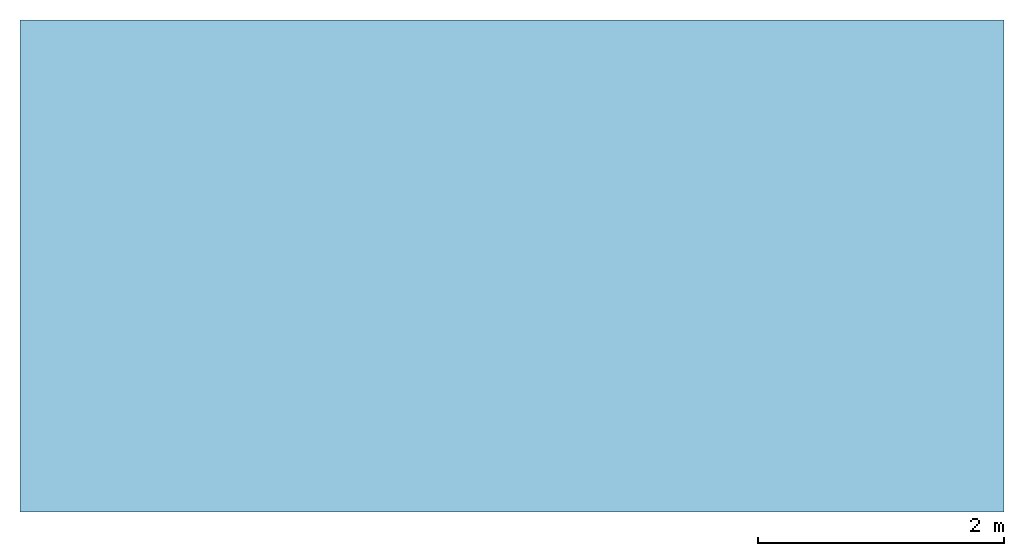
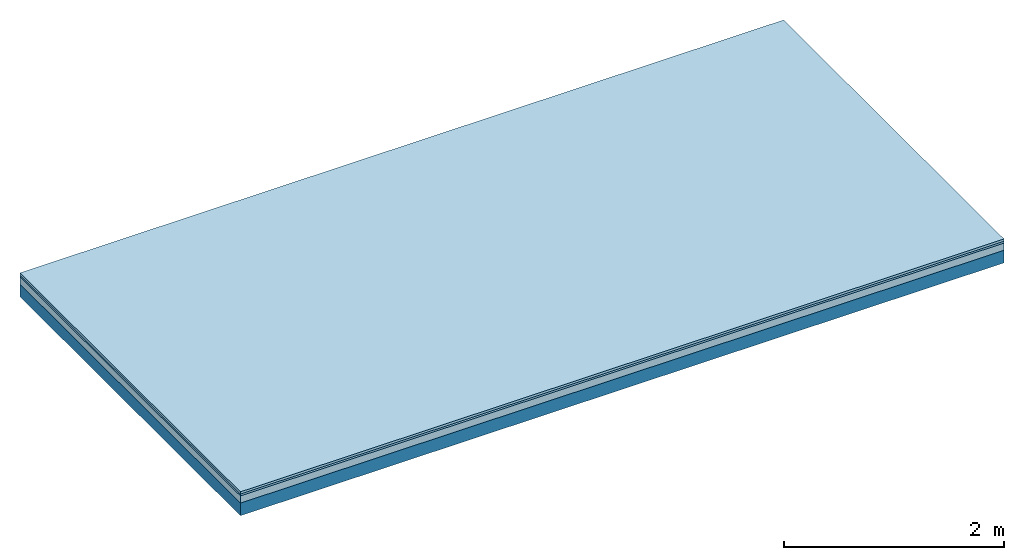
# One storey: 3 plates, 1 member, 1 element without a shape of its own.
"""IFC4 building model written with IfcOpenShell, lengths in metres."""

from ifc_helpers import new_model, si_unit, derived_unit, direction, frame, frame_2d, origin, origin_with_axes, place, context, project, spatial, rectangle, extrude, material, layer, layer_set, type_object, element, aggregate, save


model = new_model("IFC4")

# Units and contexts
plan_context = context("Plan", 3, precision=1e-05, world=origin(), true_north=direction((0.0, 1.0)))
model_context = context("Model", 3, precision=1e-05, world=origin(), true_north=direction((0.0, 1.0)))
ifc_project = project(units=[si_unit("LENGTHUNIT", "METRE"), derived_unit("SOUNDPRESSUREUNIT", [(si_unit("PRESSUREUNIT", "PASCAL", prefix="MICRO"), 0)]), si_unit("ENERGYUNIT", "JOULE", prefix="MEGA"), si_unit("MASSUNIT", "GRAM", prefix="KILO"), derived_unit("THERMALTRANSMITTANCEUNIT", [(si_unit("POWERUNIT", "WATT"), 1), (si_unit("AREAUNIT", "SQUARE_METRE"), -1), (si_unit("THERMODYNAMICTEMPERATUREUNIT", "KELVIN"), -1)]), derived_unit("AREADENSITYUNIT", [(si_unit("MASSUNIT", "GRAM", prefix="KILO"), 1), (si_unit("AREAUNIT", "SQUARE_METRE"), -1)]), derived_unit("USERDEFINED", [(si_unit("ENERGYUNIT", "JOULE", prefix="MEGA"), 1), (si_unit("AREAUNIT", "SQUARE_METRE"), -1)])], contexts=[plan_context, model_context])

# Site, building, storey
site = spatial("IfcSite", under=ifc_project)
building_placement = place(None, origin())
building = spatial("IfcBuilding", under=site, at=building_placement)
storey_placement = place(building_placement, origin())
storey = spatial("IfcBuildingStorey", under=building, at=storey_placement)

# Slab, member, plates
ifc_material_1 = material(Name="Phone TRI ST Star", Category="03.013")
ifc_layer_1 = layer(ifc_material_1, 0.025, Name="On-material")
ifc_material_2 = material(Name="EP3")
ifc_layer_2 = layer(ifc_material_2, 0.02, Name="Impact sound insulation")
ifc_material_3 = material(Category="03.011")
ifc_layer_3 = layer(ifc_material_3, 0.08, Name="on Supporting structure")
ifc_material_4 = material(Name="no composite action")
ifc_layer_4 = layer(ifc_material_4, 0.0, Name="Bond")
ifc_layer_5 = layer(None, 0.14, Name="Supporting structure")
ifc_layer_set = layer_set([ifc_layer_1, ifc_layer_2, ifc_layer_3, ifc_layer_4, ifc_layer_5])
slab_type = type_object("IfcSlabType", Name="A2433", PredefinedType="NOTDEFINED", material=ifc_layer_set)
slab_placement = place(None, frame((0.0, 0.0, 0.0), z_axis=(0.0, 0.0, -1.0), x_axis=(1.0, 0.0, 0.0)))
slab = element("IfcSlab", 1, at=slab_placement, inside=storey, type_object=slab_type, material=ifc_layer_set, Name="Slab #1")
ifc_material_5 = material()
member_placement = place(slab_placement, origin())
member = element("IfcMember", 2, at=member_placement, material=ifc_material_5, Name="Supporting structure", context=plan_context, shape_type="SweptSolid", body=[
    extrude(rectangle(XDim=1.0, YDim=0.14, at=frame_2d((0.5, 0.07), x_axis=(1.0, 0.0))), frame((0.0, 4.0, 0.125), z_axis=(0.0, -1.0, 0.0), x_axis=(1.0, 0.0, 0.0)), (0.0, 0.0, 1.0), 4.0),
    extrude(rectangle(XDim=1.0, YDim=0.14, at=frame_2d((0.5, 0.07), x_axis=(1.0, 0.0))), frame((1.0, 4.0, 0.125), z_axis=(0.0, -1.0, 0.0), x_axis=(1.0, 0.0, 0.0)), (0.0, 0.0, 1.0), 4.0),
    extrude(rectangle(XDim=1.0, YDim=0.14, at=frame_2d((0.5, 0.07), x_axis=(1.0, 0.0))), frame((2.0, 4.0, 0.125), z_axis=(0.0, -1.0, 0.0), x_axis=(1.0, 0.0, 0.0)), (0.0, 0.0, 1.0), 4.0),
    extrude(rectangle(XDim=1.0, YDim=0.14, at=frame_2d((0.5, 0.07), x_axis=(1.0, 0.0))), frame((3.0, 4.0, 0.125), z_axis=(0.0, -1.0, 0.0), x_axis=(1.0, 0.0, 0.0)), (0.0, 0.0, 1.0), 4.0),
    extrude(rectangle(XDim=1.0, YDim=0.14, at=frame_2d((0.5, 0.07), x_axis=(1.0, 0.0))), frame((4.0, 4.0, 0.125), z_axis=(0.0, -1.0, 0.0), x_axis=(1.0, 0.0, 0.0)), (0.0, 0.0, 1.0), 4.0),
    extrude(rectangle(XDim=1.0, YDim=0.14, at=frame_2d((0.5, 0.07), x_axis=(1.0, 0.0))), frame((5.0, 4.0, 0.125), z_axis=(0.0, -1.0, 0.0), x_axis=(1.0, 0.0, 0.0)), (0.0, 0.0, 1.0), 4.0),
    extrude(rectangle(XDim=1.0, YDim=0.14, at=frame_2d((0.5, 0.07), x_axis=(1.0, 0.0))), frame((6.0, 4.0, 0.125), z_axis=(0.0, -1.0, 0.0), x_axis=(1.0, 0.0, 0.0)), (0.0, 0.0, 1.0), 4.0),
    extrude(rectangle(XDim=1.0, YDim=0.14, at=frame_2d((0.5, 0.07), x_axis=(1.0, 0.0))), frame((7.0, 4.0, 0.125), z_axis=(0.0, -1.0, 0.0), x_axis=(1.0, 0.0, 0.0)), (0.0, 0.0, 1.0), 4.0),
])
plate_1_placement = place(slab_placement, origin())
plate_1 = element("IfcPlate", 3, at=plate_1_placement, material=ifc_material_1, Name="On-material", context=plan_context, shape_type="SweptSolid", body=[
    extrude(rectangle(XDim=8.0, YDim=4.0, at=frame_2d((4.0, 2.0), x_axis=(1.0, 0.0))), origin_with_axes(), (0.0, 0.0, 1.0), 0.025),
])
plate_2_placement = place(slab_placement, origin())
plate_2 = element("IfcPlate", 4, at=plate_2_placement, material=ifc_material_2, Name="Impact sound insulation", context=plan_context, shape_type="SweptSolid", body=[
    extrude(rectangle(XDim=8.0, YDim=4.0, at=frame_2d((4.0, 2.0), x_axis=(1.0, 0.0))), frame((0.0, 0.0, 0.025), z_axis=(0.0, 0.0, 1.0), x_axis=(1.0, 0.0, 0.0)), (0.0, 0.0, 1.0), 0.02),
])
plate_3_placement = place(slab_placement, origin())
plate_3 = element("IfcPlate", 5, at=plate_3_placement, material=ifc_material_3, Name="on Supporting structure", context=plan_context, shape_type="SweptSolid", body=[
    extrude(rectangle(XDim=8.0, YDim=4.0, at=frame_2d((4.0, 2.0), x_axis=(1.0, 0.0))), frame((0.0, 0.0, 0.045), z_axis=(0.0, 0.0, 1.0), x_axis=(1.0, 0.0, 0.0)), (0.0, 0.0, 1.0), 0.08),
])
aggregate(slab, [plate_1, plate_2, plate_3, member])

save(model, "model.ifc")
